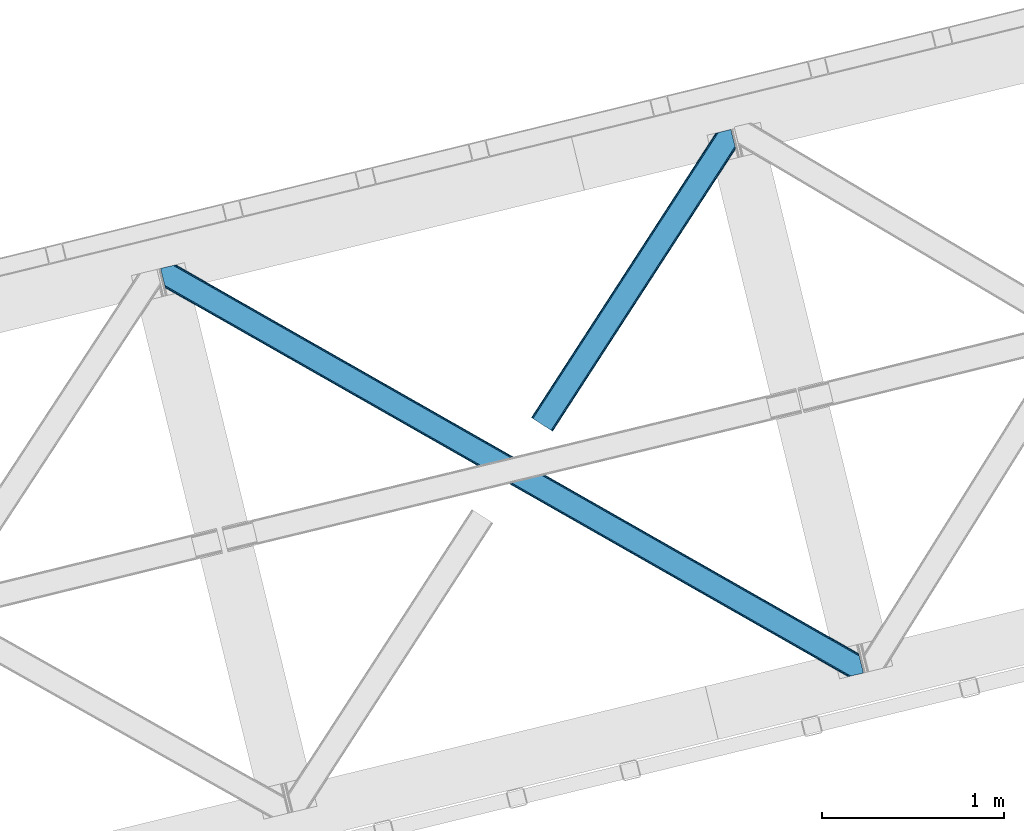
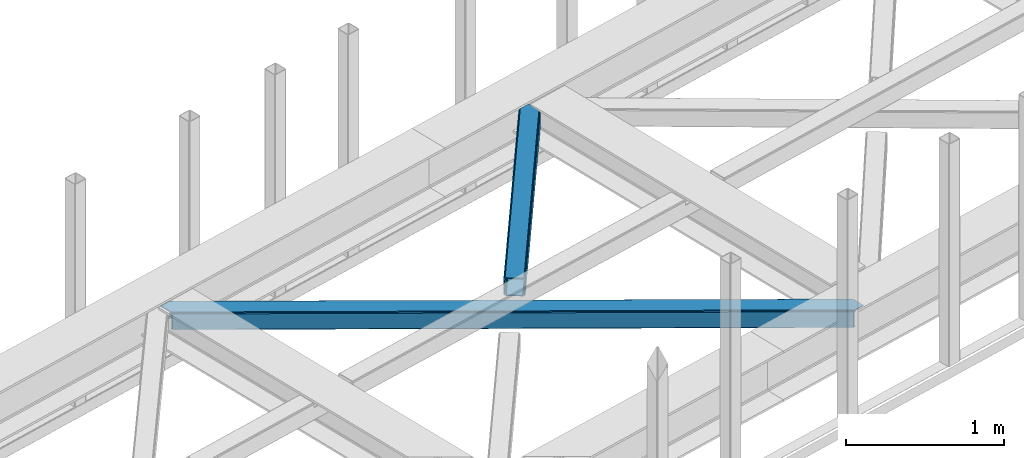
# One storey, part 37 of 66: 2 members.
"""IFC4 building model written with IfcOpenShell, lengths in millimetres."""

from ifc_helpers import new_model, entity, si_unit, converted_unit, derived_unit, direction, frame, origin, place, context, subcontext, project, spatial, triangles, type_object, element, save


model = new_model("IFC4")

# Units and contexts
model_context = context("Model", 3, precision=0.01, world=origin(), true_north=direction((6.12303176911189e-17, 1.0)))
plan_context = context("Plan", 3, precision=0.01, world=origin(), true_north=direction((6.12303176911189e-17, 1.0)))
body_context = subcontext(model_context, "Body", "Model", "MODEL_VIEW")
ifc_project = project(units=[si_unit("LENGTHUNIT", "METRE", prefix="MILLI"), si_unit("AREAUNIT", "SQUARE_METRE"), si_unit("VOLUMEUNIT", "CUBIC_METRE"), converted_unit("PLANEANGLEUNIT", "DEGREE", entity("IfcRatioMeasure", 0.0174532925199433), si_unit("PLANEANGLEUNIT", "RADIAN"), dimensions=[0, 0, 0, 0, 0, 0, 0]), si_unit("MASSUNIT", "GRAM", prefix="KILO"), derived_unit("MASSDENSITYUNIT", [(si_unit("MASSUNIT", "GRAM", prefix="KILO"), 1), (si_unit("LENGTHUNIT", "METRE"), -3)]), derived_unit("MOMENTOFINERTIAUNIT", [(si_unit("LENGTHUNIT", "METRE"), 4)]), si_unit("TIMEUNIT", "SECOND"), si_unit("FREQUENCYUNIT", "HERTZ"), si_unit("THERMODYNAMICTEMPERATUREUNIT", "DEGREE_CELSIUS"), derived_unit("THERMALTRANSMITTANCEUNIT", [(si_unit("MASSUNIT", "GRAM", prefix="KILO"), 1), (si_unit("THERMODYNAMICTEMPERATUREUNIT", "KELVIN"), -1), (si_unit("TIMEUNIT", "SECOND"), -3)]), derived_unit("VOLUMETRICFLOWRATEUNIT", [(si_unit("LENGTHUNIT", "METRE"), 3), (si_unit("TIMEUNIT", "SECOND"), -1)]), derived_unit("MASSFLOWRATEUNIT", [(si_unit("MASSUNIT", "GRAM", prefix="KILO"), 1), (si_unit("TIMEUNIT", "SECOND"), -1)]), derived_unit("ROTATIONALFREQUENCYUNIT", [(si_unit("TIMEUNIT", "SECOND"), -1)]), si_unit("ELECTRICCURRENTUNIT", "AMPERE"), si_unit("ELECTRICVOLTAGEUNIT", "VOLT"), si_unit("POWERUNIT", "WATT"), si_unit("FORCEUNIT", "NEWTON", prefix="KILO"), si_unit("ILLUMINANCEUNIT", "LUX"), si_unit("LUMINOUSFLUXUNIT", "LUMEN"), si_unit("LUMINOUSINTENSITYUNIT", "CANDELA"), derived_unit("USERDEFINED", [(si_unit("MASSUNIT", "GRAM", prefix="KILO"), -1), (si_unit("LENGTHUNIT", "METRE"), -2), (si_unit("TIMEUNIT", "SECOND"), 3), (si_unit("LUMINOUSFLUXUNIT", "LUMEN"), 1)]), derived_unit("LINEARVELOCITYUNIT", [(si_unit("LENGTHUNIT", "METRE"), 1), (si_unit("TIMEUNIT", "SECOND"), -1)]), si_unit("PRESSUREUNIT", "PASCAL"), derived_unit("USERDEFINED", [(si_unit("LENGTHUNIT", "METRE"), -2), (si_unit("MASSUNIT", "GRAM", prefix="KILO"), 1), (si_unit("TIMEUNIT", "SECOND"), -2)]), derived_unit("LINEARFORCEUNIT", [(si_unit("MASSUNIT", "GRAM", prefix="KILO"), 1), (si_unit("LENGTHUNIT", "METRE"), 1), (si_unit("TIMEUNIT", "SECOND"), -2), (si_unit("LENGTHUNIT", "METRE"), -1)]), derived_unit("PLANARFORCEUNIT", [(si_unit("MASSUNIT", "GRAM", prefix="KILO"), 1), (si_unit("LENGTHUNIT", "METRE"), 1), (si_unit("TIMEUNIT", "SECOND"), -2), (si_unit("LENGTHUNIT", "METRE"), -2)])], contexts=[model_context, plan_context])

# Site, building, storey
site_placement = place(None, origin())
site = spatial("IfcSite", under=ifc_project, at=site_placement, CompositionType="ELEMENT")
building_placement = place(site_placement, origin())
building = spatial("IfcBuilding", under=site, at=building_placement, CompositionType="ELEMENT")
storey_placement = place(building_placement, frame((0.0, 0.0, 19800.0)))
storey = spatial("IfcBuildingStorey", under=building, at=storey_placement, Name="06", CompositionType="ELEMENT", Elevation=19800.0)

# Members
member_type_1 = type_object("IfcMemberType", PredefinedType="BRACE")
member_1_placement = place(storey_placement, frame((-33302.32, 10419.12, 3823.06)))
element("IfcMember", 1, at=member_1_placement, inside=storey, type_object=member_type_1, ObjectType="Steel Horizontal Brace", PredefinedType="BRACE", context=body_context, shape_type="Tessellation", body=[
    triangles([(3770.60705566406, 0.0, 122.478570556643), (3772.49298706055, 0.459274291992188, 129.175836181643), (25.7193603515625, 2133.71162109375, 130.119964599609), (26.1542175292998, 2131.93149719238, 123.422698974609), (3777.86242675781, 1.767333984375, 134.852233886719), (24.4845520019517, 2138.77991638184, 135.79868774414), (3785.89449462891, 3.72651672363281, 138.645025634767), (22.6358276367173, 2146.36666259766, 139.593804931643), (3795.37298583984, 6.03684082031214, 139.975177001954), (20.454565429689, 2155.31379089356, 140.926281738281), (1898.4864440918, 1065.90586853027, 17.9500671386741), (2530.61995239258, 705.99644165039, 17.7919372558608), (3162.75346069336, 346.087014770508, 17.631481933593), (3770.60705566406, 0.0, 17.478002929689), (1266.35293579102, 1425.81529541016, 18.1105224609382), (26.1542175292998, 2131.93149719238, 18.4221313476555), (634.22175292969, 1785.72355957031, 18.2686523437515), (3834.64500732422, 104.50408630371, 139.977502441408), (3855.09957275391, 20.5952545166019, 139.963549804688), (59.7242614746137, 2253.78103637695, 140.93093261719), (0.0, 2239.22262268066, 140.940234375001), (3832.46607055664, 113.452377319336, 138.647351074218), (69.2027526855454, 2256.09136047363, 139.596130371094), (3830.61502075195, 121.037960815429, 134.854559326173), (77.2371459960923, 2258.04938049316, 135.801013183594), (3829.38021240235, 126.106256103516, 129.178161621094), (82.6065856933637, 2259.35860290527, 130.122290039064), (3828.94535522461, 127.886380004882, 122.480895996094), (84.490191650395, 2259.81787719727, 123.425024414064), (3220.89642333984, 474.082690429686, 17.6338073730476), (3828.94535522461, 127.886380004882, 17.4803283691399), (2588.76291503906, 833.99211730957, 17.7942626953118), (1956.62940673828, 1193.90154418945, 17.9547180175796), (1324.4958984375, 1553.81097106934, 18.1128479003928), (692.364715576172, 1913.72156066894, 18.273303222657), (84.490191650395, 2259.81787719727, 18.4267822265647), (3832.89627685547, 111.685043334961, 127.852661132813), (3832.89627685547, 111.685043334961, 12.1039123535156), (3833.99853515625, 107.15973815918, 9.46221313476781), (3829.58020019531, 125.287701416015, 9.46221313476781), (3831.65914306641, 116.753338623046, 122.176263427737), (3834.7450012207, 104.098297119141, 131.645452880861), (3836.92626342774, 95.1500061035149, 132.975604248048), (3855.09957275391, 20.5952545166019, 132.963977050782), (3831.22661132813, 118.533462524414, 115.478997802737), (3831.22661132813, 118.533462524414, 24.4799011230461), (3831.65914306641, 116.753338623046, 17.7826354980461), (3829.47090454102, 125.737673950194, 10.8528259277336), (1952.50407714844, 1188.19607849121, 24.9542907714858), (74.5838195800825, 2257.4029083252, 116.427777099609), (2588.61641235352, 826.021673583984, 24.793835449218), (3224.72874755859, 463.846105957031, 24.6333801269539), (1316.39406738281, 1550.37164611816, 25.11474609375), (74.5838195800825, 2257.4029083252, 25.4263549804709), (680.279406738282, 1912.54721374512, 25.2752014160178), (72.7002136230512, 2256.9436340332, 123.125042724609), (67.3307739257798, 2255.63557434082, 128.803765869143), (59.2940551757856, 2253.67639160156, 132.598883056642), (49.8202148437485, 2251.36723022461, 133.931359863283), (0.0, 2239.22262268066, 133.940661621094), (67.3307739257798, 2255.63557434082, 13.0550170898459), (81.762451171875, 2259.1539642334, 10.4412231445313), (72.7002136230512, 2256.9436340332, 18.7314147949219), (62.6054809570342, 2254.4833190918, 10.4412231445313), (82.2252136230454, 2259.26558532715, 11.7946289062493), (3805.27935791016, 8.45180969238208, 132.973278808593), (18.1733093261719, 2164.66787109375, 133.929034423829), (3795.80319213867, 6.14148559570276, 131.643127441406), (20.3545715332075, 2155.71958007812, 132.594232177737), (3787.76879882813, 4.18230285644495, 127.850335693362), (22.2032958984419, 2148.13399658203, 128.799114990234), (3782.39935913086, 2.87424316406214, 122.173937988282), (23.4404296875, 2143.06453857422, 123.122717285158), (3780.51342773438, 2.41496887206995, 115.476672363282), (23.8729614257827, 2141.28441467285, 116.425451660158), (3174.86434936523, 347.246246337891, 24.6287292480483), (3780.51342773438, 2.41496887206995, 24.4775756835952), (2538.75433959961, 709.420651245116, 24.7891845703125), (1902.64200439453, 1071.59505615234, 24.9496398925803), (1266.52966918945, 1433.76946105957, 25.1100952148445), (630.417333984376, 1795.9438659668, 25.2705505371086), (23.8729614257827, 2141.28441467285, 25.4240295410164), (23.4404296875, 2143.06453857422, 18.7267639160164), (25.526348876956, 2134.50575866699, 10.4412231445313), (22.2032958984419, 2148.13399658203, 13.0503662109368), (25.6333190918012, 2134.06973876953, 11.7923034667983), (21.1173156738296, 2152.58837585449, 10.4412231445313), (3787.76879882813, 4.18230285644495, 12.1015869140647), (3773.35805053711, 0.669726562498909, 9.46221313476781), (3782.39935913086, 2.87424316406214, 17.7803100585952), (3792.55455322266, 5.34967346191297, 9.46221313476781), (3772.88133544922, 0.554617309569949, 10.8481750488281), (3697.37896728516, 59.5847351074208, 9.46221313476781), (3701.80660400391, 41.4207275390618, 9.46221313476781), (153.281341552734, 2218.44482116699, 10.4412231445313), (157.68107299805, 2200.39708557129, 10.4412231445313), (154.658001708987, 2217.02514038086, 9.4412841796875), (159.494915771487, 2197.17402648926, 9.4412841796875), (159.143774414064, 2198.29140014648, 9.82498168945313), (154.325463867186, 2217.3681427002, 9.68312988281468), (158.657757568362, 2198.98903198242, 10.0296203613289), (153.969671630861, 2217.73439941406, 9.94125366210938), (158.167089843751, 2199.69829101562, 10.2365844726555), (153.613879394536, 2218.10181884766, 10.1993774414077), (193.244018554688, 2054.50599060059, 10.4412231445313), (197.636773681639, 2036.48848571777, 10.4412231445313), (193.823052978514, 2056.35122680664, 9.4412841796875), (198.650665283203, 2036.54313354492, 9.4412841796875), (193.769567871095, 2055.7105682373, 9.74824218749927), (198.466955566408, 2036.45825500488, 9.74126586914281), (193.713757324222, 2055.05479431152, 10.0598510742202), (198.266967773438, 2036.36523742676, 10.0668273925803), (193.657946777348, 2054.41297302246, 10.366809082032), (198.078607177733, 2036.27919616699, 10.366809082032), (3701.47406616211, 41.764892578125, 9.22036743164063), (3696.87899780273, 60.0172668457035, 9.38547363281396), (3701.11827392578, 42.1334747314449, 8.96224365234593), (3696.43716430664, 60.9648834228519, 9.07851562500218), (3700.76248168945, 42.5032196044922, 8.7041198730476), (3695.99067993164, 61.9218017578114, 8.76923217773583), (3700.42994384766, 42.8473846435536, 8.46227416992406), (3695.54884643555, 62.8694183349598, 8.46227416992406), (3163.41156005859, 347.245083618163, 10.934216308593), (634.879852294922, 1786.8827911377, 11.5737121582024), (636.754156494142, 1790.1791015625, 5.89498901367188), (197.780950927736, 2040.11268310547, 6.0066101074226), (3165.28586425781, 350.542556762695, 5.25781860351708), (3699.57883300781, 46.3401947021484, 5.1229431152351), (3697.72778320313, 53.9257781982415, 1.33015136718677), (3168.09499511719, 355.4759765625, 1.46502685546875), (3695.5465209961, 62.8740692138672, 0.0), (3171.40874633789, 361.296551513671, 0.132550048827397), (642.877038574221, 1800.9342590332, 0.76972045898583), (639.563287353518, 1795.11368408203, 2.10219726562718), (195.932226562501, 2047.69826660156, 2.21381835937427), (193.750964355473, 2056.64655761719, 0.8836669921875), (2539.27523803711, 721.205978393555, 0.290679931640625), (2535.96148681641, 715.385403442382, 1.62315673828198), (1907.14172973633, 1081.11540527344, 0.451135253908433), (1903.82797851563, 1075.29483032227, 1.78361206054615), (1275.00822143555, 1441.02483215332, 0.609265136718022), (1271.69447021485, 1435.20425720215, 1.94174194335938), (2533.15235595703, 710.451983642577, 5.41594848633031), (1901.01884765625, 1070.36141052246, 5.57640380859448), (1268.88766479492, 1430.27083740234, 5.73685913085865), (2531.27805175781, 707.154510498047, 11.0946716308608), (1899.14454345703, 1067.06393737793, 11.2528015136741), (1267.01103515625, 1426.97336425781, 11.4132568359382), (3661.34860839844, 203.171319580078, 0.0209289550803078), (3212.23416137695, 458.877804565429, 0.134875488281978), (2580.10297851563, 818.787231445313, 0.293005371095205), (1947.96947021484, 1178.69665832519, 0.453460693359375), (683.702453613281, 1898.51551208496, 0.772045898436772), (1315.83596191406, 1538.60608520508, 0.613916015627183), (159.553051757815, 2196.9438079834, 0.904595947267808), (3177.39675292969, 351.70062561035, 12.2550659179688), (3180.20588378907, 356.635208129883, 8.46227416992406), (3695.44420166016, 63.299624633788, 8.39483642578125), (3693.26759033203, 72.2269866943352, 7.00189819336083), (639.072619628907, 1811.15340270996, 7.77161865234302), (191.472033691411, 2065.99947509766, 7.88323974609375), (193.643994140628, 2057.08722839356, 9.32268676758031), (632.952062988283, 1800.39940795898, 12.8968872070327), (635.758868408204, 1805.33399047852, 9.10409545898438), (631.075433349612, 1797.10309753418, 18.5756103515632), (3183.51963500977, 362.455783081054, 7.12979736328271), (3175.52244873047, 348.404315185546, 17.9337890624993), (2539.41011352539, 710.578720092773, 18.0942443847671), (1903.30010375977, 1072.753125, 18.2546997070313), (1267.18776855469, 1434.92752990723, 18.4151550292991), (2541.28674316406, 713.876193237304, 12.4155212402366), (1905.17440795898, 1076.05059814453, 12.5759765625007), (1269.06439819336, 1438.22500305176, 12.7364318847649), (2544.09587402344, 718.810775756836, 8.62272949218823), (1907.98353881836, 1080.98518066406, 8.7831848144524), (1271.87352905274, 1443.15958557129, 8.94364013672021), (2547.40962524414, 724.630187988281, 7.29025268554688), (1911.29729003906, 1086.80459289551, 7.45070800781468), (1275.18495483399, 1448.97899780273, 7.61116333007885), (155.520739746098, 2213.47884521484, 6.03218994140843), (157.37178955078, 2205.89209899902, 2.23707275390552), (161.831982421878, 2187.59089050293, 7.90416870117406), (159.657696533206, 2196.50778808594, 9.33431396484593), (3216.0664855957, 448.640057373046, 7.13212280273365), (2579.95647583008, 810.815624999999, 7.29257812500146), (1943.84181518555, 1172.99119262695, 7.45303344726563), (3663.6275390625, 193.818402099609, 7.02050170898656), (671.617144775391, 1897.34000244141, 7.7739440917976), (1307.72947998047, 1535.16559753418, 7.61348876953343), (3220.23832397461, 472.926947021484, 10.9365417480476), (3218.35704345703, 469.630636596679, 5.26014404296802), (3656.48843994141, 223.423571777343, 8.84597167968968), (3656.47216186524, 223.174749755859, 8.46227416992406), (3657.48372802735, 223.244512939453, 9.46221313476781), (3656.81400146485, 223.365435791015, 9.04595947265625), (3657.31862182617, 219.705194091797, 5.14852294922093), (691.704290771486, 1912.56465454101, 11.576037597657), (689.82533569336, 1909.26834411621, 5.89731445312646), (687.016204833984, 1904.33492431641, 2.10452270507813), (3659.16734619141, 212.119610595702, 1.3557312011726), (3215.54791259766, 464.697216796874, 1.46735229492333), (2588.10481567383, 832.836373901368, 11.0969970703118), (1955.97130737305, 1192.74580078125, 11.2574523925796), (1323.83779907227, 1552.65522766113, 11.4155822753928), (2586.22353515625, 829.540063476563, 5.42059936523583), (1954.09235229492, 1189.44949035644, 5.57872924804906), (1321.95884399414, 1549.35891723633, 5.73918457031323), (2583.41440429688, 824.606643676758, 1.62548217773656), (1951.28322143555, 1184.51607055664, 1.78593750000073), (1319.14971313477, 1544.42549743652, 1.94406738281396), (674.930895996094, 1903.16057739258, 9.10642089843896), (677.742352294925, 1908.09399719238, 12.8992126464836), (3661.36256103516, 203.10969543457, 8.46227416992406), (3661.92066650391, 205.049111938477, 9.46221313476781), (3222.19169311524, 459.394052124024, 12.2573913574233), (3219.38023681641, 454.459469604491, 8.464599609375), (3661.30209960938, 203.975921630859, 8.81574096679833), (3661.24396362305, 204.843310546874, 9.1692077636726), (679.618981933596, 1911.38914489746, 18.5779357910178), (3224.06832275391, 462.689199829101, 17.9361145019539), (2583.26790161133, 816.635037231445, 8.62505493164281), (1947.15556640625, 1178.8106048584, 8.78551025390698), (1311.04323120117, 1540.98500976563, 8.94596557617115), (2586.0770324707, 821.56845703125, 12.4178466796875), (1949.96469726563, 1183.74286193848, 12.5783020019553), (1313.8546875, 1545.91842956543, 12.7387573242195), (2587.95598754883, 824.864767456054, 18.096569824218), (1951.84365234375, 1187.04033508301, 18.2570251464858), (1315.73131713867, 1549.21473999023, 18.41748046875)], [[1, 2, 3], [3, 4, 1], [2, 5, 6], [6, 3, 2], [5, 7, 8], [8, 6, 5], [7, 9, 10], [10, 8, 7], [11, 1, 4], [1, 12, 13], [11, 12, 1], [13, 14, 1], [15, 11, 4], [4, 16, 17], [17, 15, 4], [9, 18, 10], [9, 19, 18], [20, 10, 18], [21, 10, 20], [18, 22, 23], [23, 20, 18], [22, 24, 25], [25, 23, 22], [24, 26, 27], [27, 25, 24], [26, 28, 29], [29, 27, 26], [30, 28, 31], [28, 30, 32], [28, 33, 29], [33, 28, 32], [29, 33, 34], [34, 35, 29], [36, 29, 35], [37, 24, 22], [38, 39, 40], [24, 37, 41], [42, 37, 22], [42, 18, 43], [19, 43, 18], [43, 19, 44], [42, 22, 18], [31, 45, 46], [40, 47, 38], [47, 31, 46], [48, 47, 40], [48, 31, 47], [28, 45, 31], [41, 26, 24], [28, 26, 41], [45, 28, 41], [49, 45, 50], [45, 51, 52], [49, 51, 45], [52, 46, 45], [53, 49, 50], [50, 54, 55], [55, 53, 50], [45, 41, 50], [56, 50, 41], [41, 37, 56], [57, 56, 37], [37, 42, 57], [58, 57, 42], [42, 43, 58], [59, 58, 43], [56, 29, 27], [58, 23, 20], [21, 59, 20], [59, 21, 60], [59, 58, 20], [57, 23, 58], [57, 56, 25], [25, 23, 57], [27, 25, 56], [54, 36, 29], [61, 62, 63], [56, 50, 29], [61, 64, 62], [54, 63, 36], [50, 54, 29], [65, 36, 63], [63, 62, 65], [43, 66, 67], [66, 43, 44], [67, 59, 43], [60, 59, 67], [66, 68, 67], [69, 67, 68], [68, 70, 69], [71, 69, 70], [70, 72, 71], [73, 71, 72], [72, 74, 73], [75, 73, 74], [76, 74, 77], [74, 76, 78], [74, 79, 75], [79, 74, 78], [75, 79, 80], [80, 81, 75], [82, 75, 81], [83, 84, 85], [82, 4, 16], [16, 86, 83], [86, 84, 83], [83, 82, 16], [75, 4, 82], [73, 71, 6], [3, 73, 6], [3, 4, 73], [75, 73, 4], [71, 8, 6], [69, 8, 71], [87, 85, 84], [69, 67, 10], [69, 10, 8], [67, 21, 10], [67, 60, 21], [72, 1, 2], [68, 7, 9], [66, 19, 44], [9, 66, 68], [66, 9, 19], [70, 7, 68], [70, 72, 5], [5, 7, 70], [2, 5, 72], [14, 1, 74], [88, 89, 90], [72, 74, 1], [88, 91, 89], [77, 90, 14], [77, 14, 74], [92, 14, 90], [90, 89, 92], [91, 89, 93], [94, 93, 89], [95, 96, 62], [64, 62, 96], [97, 98, 99], [100, 99, 101], [102, 101, 103], [104, 103, 96], [96, 95, 104], [103, 104, 102], [101, 102, 100], [99, 100, 97], [105, 106, 84], [84, 87, 105], [107, 108, 109], [110, 109, 108], [109, 110, 111], [112, 111, 110], [111, 112, 113], [114, 113, 112], [113, 114, 106], [106, 105, 113], [115, 116, 93], [117, 118, 116], [119, 120, 118], [121, 122, 120], [120, 119, 121], [118, 117, 119], [116, 115, 117], [93, 94, 115], [123, 92, 14], [124, 17, 16], [110, 125, 112], [110, 108, 125], [114, 112, 125], [108, 126, 125], [124, 86, 106], [106, 125, 124], [106, 114, 125], [86, 84, 106], [92, 123, 94], [123, 127, 128], [128, 121, 123], [115, 123, 117], [115, 94, 123], [123, 119, 117], [123, 121, 119], [94, 89, 92], [129, 128, 127], [127, 130, 129], [131, 129, 130], [130, 132, 131], [133, 134, 135], [135, 136, 133], [134, 125, 126], [126, 135, 134], [16, 86, 124], [14, 13, 123], [132, 130, 137], [138, 137, 130], [137, 138, 139], [140, 139, 138], [139, 140, 141], [142, 141, 140], [141, 142, 133], [134, 133, 142], [130, 127, 143], [143, 138, 130], [138, 143, 144], [144, 140, 138], [140, 144, 145], [145, 142, 140], [142, 145, 125], [125, 134, 142], [127, 123, 143], [146, 143, 123], [143, 146, 144], [147, 144, 146], [144, 147, 145], [148, 145, 147], [145, 148, 125], [124, 125, 148], [123, 13, 12], [12, 146, 123], [146, 12, 11], [11, 147, 146], [147, 11, 15], [15, 148, 147], [148, 15, 17], [17, 124, 148], [149, 131, 132], [150, 132, 137], [132, 150, 149], [151, 139, 152], [137, 151, 150], [151, 137, 139], [133, 153, 154], [152, 141, 154], [141, 152, 139], [141, 133, 154], [136, 153, 133], [155, 153, 136], [156, 116, 118], [118, 157, 156], [118, 120, 157], [122, 157, 120], [122, 158, 157], [88, 91, 93], [93, 156, 88], [93, 116, 156], [157, 158, 159], [160, 161, 162], [163, 113, 105], [105, 85, 163], [105, 87, 85], [164, 162, 107], [107, 163, 164], [163, 109, 111], [109, 163, 107], [111, 113, 163], [81, 165, 82], [83, 82, 165], [165, 163, 83], [85, 83, 163], [162, 164, 160], [159, 166, 157], [90, 88, 156], [156, 167, 90], [77, 90, 167], [167, 76, 77], [76, 167, 168], [168, 78, 76], [78, 168, 79], [169, 79, 168], [79, 169, 80], [170, 80, 169], [80, 170, 81], [165, 81, 170], [167, 156, 168], [171, 168, 156], [168, 171, 172], [172, 169, 168], [169, 172, 173], [173, 170, 169], [170, 173, 163], [163, 165, 170], [156, 157, 174], [174, 171, 156], [171, 174, 172], [175, 172, 174], [172, 175, 173], [176, 173, 175], [173, 176, 163], [164, 163, 176], [157, 166, 174], [177, 174, 166], [174, 177, 178], [178, 175, 174], [175, 178, 179], [179, 176, 175], [176, 179, 160], [160, 164, 176], [98, 180, 181], [155, 98, 181], [182, 183, 155], [182, 155, 161], [180, 98, 97], [155, 183, 98], [161, 136, 162], [136, 135, 107], [136, 161, 155], [126, 107, 135], [136, 107, 162], [126, 108, 107], [177, 166, 184], [184, 185, 177], [185, 178, 177], [178, 185, 186], [166, 187, 184], [166, 159, 187], [188, 160, 189], [160, 188, 161], [182, 161, 188], [179, 189, 160], [186, 179, 178], [189, 179, 186], [190, 30, 31], [191, 192, 193], [190, 48, 194], [194, 191, 190], [194, 195, 191], [48, 40, 194], [193, 196, 191], [65, 197, 95], [197, 198, 180], [180, 97, 197], [197, 97, 102], [102, 95, 197], [197, 65, 36], [36, 35, 197], [95, 62, 65], [198, 199, 181], [181, 180, 198], [199, 153, 155], [155, 181, 199], [200, 149, 150], [150, 201, 200], [196, 200, 201], [201, 191, 196], [31, 48, 190], [30, 190, 32], [202, 32, 190], [32, 202, 33], [203, 33, 202], [33, 203, 34], [204, 34, 203], [34, 204, 197], [197, 35, 34], [190, 191, 205], [205, 202, 190], [202, 205, 206], [206, 203, 202], [203, 206, 207], [207, 204, 203], [204, 207, 198], [198, 197, 204], [191, 201, 205], [208, 205, 201], [205, 208, 206], [209, 206, 208], [206, 209, 207], [210, 207, 209], [207, 210, 198], [199, 198, 210], [201, 150, 208], [151, 208, 150], [208, 151, 152], [152, 209, 208], [209, 152, 154], [154, 210, 209], [210, 154, 153], [153, 199, 210], [211, 99, 183], [212, 103, 101], [212, 96, 103], [101, 211, 212], [101, 99, 211], [61, 64, 96], [96, 212, 61], [211, 183, 182], [184, 187, 213], [214, 38, 215], [214, 39, 38], [213, 215, 216], [217, 218, 215], [215, 213, 217], [213, 216, 184], [182, 188, 211], [212, 219, 63], [63, 61, 212], [219, 55, 54], [54, 63, 219], [47, 46, 220], [52, 220, 46], [38, 47, 215], [220, 215, 47], [184, 216, 185], [221, 185, 216], [185, 221, 186], [222, 186, 221], [186, 222, 189], [223, 189, 222], [189, 223, 188], [211, 188, 223], [216, 215, 224], [224, 221, 216], [221, 224, 225], [225, 222, 221], [222, 225, 226], [226, 223, 222], [223, 226, 212], [212, 211, 223], [215, 220, 224], [227, 224, 220], [224, 227, 225], [228, 225, 227], [225, 228, 226], [229, 226, 228], [226, 229, 212], [219, 212, 229], [220, 52, 51], [51, 227, 220], [227, 51, 49], [49, 228, 227], [228, 49, 53], [53, 229, 228], [229, 53, 55], [55, 219, 229], [149, 187, 159], [213, 196, 193], [149, 213, 187], [213, 200, 196], [213, 149, 200], [131, 149, 159], [158, 131, 159], [128, 158, 121], [158, 129, 131], [158, 128, 129], [214, 217, 193], [217, 213, 193], [40, 39, 214], [214, 194, 40]]),
])
member_type_2 = type_object("IfcMemberType", PredefinedType="BRACE")
member_2_placement = place(storey_placement, frame((-31269.04, 11764.69, 3823.58)))
element("IfcMember", 2, at=member_2_placement, inside=storey, type_object=member_type_2, ObjectType="Steel Horizontal Brace", PredefinedType="BRACE", context=body_context, shape_type="Tessellation", body=[
    triangles([(972.968518066409, 1545.29288635254, 0.386022949220205), (1007.16875610352, 1404.99563598633, 0.365093994139897), (14.7014282226592, 66.6447692871097, 0.0), (102.814654541016, 9.54011535644531, 0.0), (1.13248901367479, 75.4349304199222, 10.8039916992202), (0.011627197265625, 76.1581420898438, 17.4989318847656), (1010.67784423828, 1635.6559753418, 17.9082092285171), (968.503674316409, 1566.80901489258, 9.6808044433601), (4.31601562500146, 73.3734283447266, 5.12526855468604), (968.640875244142, 1567.26712646485, 9.92265014648365), (968.357171630862, 1566.32067260742, 9.42268066406177), (968.210668945314, 1565.83116760254, 9.16455688476708), (968.073468017581, 1565.37421875, 8.9227111816399), (968.938531494143, 1561.82676086426, 5.51361694336083), (1012.94282226563, 1636.20826721191, 11.2760559082017), (1013.40325927734, 1636.32105102539, 9.92265014648365), (970.787255859377, 1554.24117736817, 1.71849975585792), (9.07851562500218, 70.2864074707031, 1.33247680664135), (1010.67784423828, 1635.6559753418, 122.906451416016), (0.0, 76.1395385742198, 122.499499511719), (1012.56145019531, 1636.11524963379, 129.603717041016), (1.11853637695458, 75.4140014648438, 129.196765136719), (1017.92856445313, 1637.42330932617, 135.282440185547), (4.29973754883031, 73.3490112304698, 134.873162841795), (1025.96528320313, 1639.38249206543, 139.077557373046), (9.06456298828198, 70.2608276367191, 138.668280029298), (1035.44377441406, 1641.69281616211, 140.412359619142), (14.6828247070334, 66.6191894531257, 140.000756835936), (973.040606689454, 1549.21939086914, 9.92265014648365), (972.796435546876, 1548.6089630127, 9.84823608398438), (972.833642578127, 1547.58344421387, 9.5412780761726), (972.87317504883, 1546.54862365723, 9.22966918945167), (972.912707519532, 1545.5231048584, 8.9227111816399), (1032.56255493164, 1640.99053344727, 9.92265014648365), (14.9525756835938, 66.4773376464855, 8.3320495605476), (20.5754882812507, 62.8368621826176, 6.99957275390625), (975.249774169923, 1535.93996887207, 7.38559570312646), (10.1877502441421, 69.5655212402344, 12.1248413085923), (1027.83726196289, 1639.83827819824, 12.5364440917983), (973.075488281251, 1544.85570373535, 8.81574096679833), (1022.46782226563, 1638.53021850586, 18.2128417968743), (1020.58421630859, 1638.07094421387, 24.9077819824233), (7.00422363281541, 71.6270233154301, 17.8035644531265), (5.88568725586083, 72.3502349853516, 24.5008300781265), (1004.8875, 1414.3485534668, 7.36466674804615), (96.9382690429702, 13.3456970214847, 6.99957275390625), (1007.06178588867, 1405.4363067627, 8.80411376953271), (1007.24084472656, 1404.70030517578, 8.9227111816399), (1012.06845703125, 1384.89221191406, 8.9227111816399), (1011.19874267578, 1388.46176147461, 5.488037109375), (1009.35001831055, 1396.0473449707, 1.69524536132667), (1020.58421630859, 1638.07094421387, 115.909204101561), (5.87638549804979, 72.3339569091804, 115.499926757813), (1035.87398071289, 1641.7974609375, 132.080310058594), (1045.34782104492, 1644.10778503418, 133.412786865236), (20.5592102050796, 62.8124450683608, 132.998858642579), (14.9386230468772, 66.4552459716797, 131.668707275392), (1027.83726196289, 1639.83827819824, 128.285192871095), (10.1737976074219, 69.5434295654304, 127.873590087889), (1022.46782226563, 1638.53021850586, 122.606469726561), (6.99259643554979, 71.6084197998061, 122.197192382813), (1095.16803588867, 1656.2512298584, 140.421661376953), (1095.16803588867, 1656.2512298584, 133.422088623047), (1115.62260131836, 1572.34239807129, 140.407708740233), (102.798376464845, 9.5145355224613, 140.000756835936), (1113.34134521485, 1581.69647827149, 133.410461425781), (96.92431640625, 13.3224426269535, 132.998858642579), (1117.80153808594, 1563.39526977539, 139.075231933595), (108.418963623048, 5.87289733886792, 138.668280029298), (1119.65258789063, 1555.80852355957, 135.280114746092), (113.181463623048, 2.78587646484448, 134.873162841795), (1120.88739624024, 1550.74022827148, 129.601391601562), (116.36731567383, 0.72321166992333, 129.196765136719), (1121.32225341797, 1548.96010437012, 122.904125976562), (117.485852050784, 0.0, 122.499499511719), (1121.32225341797, 1548.96010437012, 17.9035583496079), (117.499804687501, 0.0197662353530177, 17.4989318847656), (107.309729003908, 6.59378356933667, 127.873590087889), (110.495581054689, 4.53228149414099, 122.197192382813), (111.611791992189, 3.80790710449219, 115.499926757813), (102.544903564456, 9.6808044433601, 131.668707275392), (116.38126831055, 0.74530334472729, 10.8039916992202), (107.323681640628, 6.61471252441515, 12.1248413085923), (113.197741699219, 2.80913085937573, 5.12526855468604), (111.623419189455, 3.82534790039063, 24.5008300781265), (110.507208251955, 4.55088500976672, 17.8035644531265), (108.432916259768, 5.89731445312646, 1.33247680664135), (102.558856201173, 9.70289611816406, 8.3320495605476), (1118.60846557617, 1560.09314575195, 122.60414428711), (1119.04099731446, 1558.31302185059, 115.90687866211), (1117.37133178711, 1565.16260375977, 128.280541992186), (1115.52260742188, 1572.74818725586, 132.075659179689), (1119.04099731446, 1558.31302185059, 24.9054565429688), (1118.60846557617, 1560.09314575195, 18.2081909179688), (1120.69438476563, 1551.53436584473, 9.92265014648365), (1117.37133178711, 1565.16260375977, 12.5317932128892), (1120.79902954102, 1551.09834594727, 11.2737304687507), (1116.2853515625, 1569.61698303223, 9.92265014648365), (1012.19868164063, 1384.68524780274, 9.30640869140552), (1012.7358581543, 1385.10731506348, 9.72266235351708), (1012.99630737305, 1385.31079101563, 9.92265014648365), (1008.6035522461, 1403.32829589844, 9.92265014648365), (1007.57570800781, 1403.93872375488, 9.27617797851417)], [[1, 2, 3], [4, 3, 2], [5, 6, 7], [8, 9, 10], [9, 8, 11], [12, 9, 11], [9, 12, 13], [13, 14, 9], [5, 15, 10], [10, 9, 5], [15, 16, 10], [17, 1, 18], [3, 18, 1], [14, 17, 9], [18, 9, 17], [7, 15, 5], [19, 7, 20], [6, 20, 7], [21, 19, 22], [20, 22, 19], [23, 21, 24], [22, 24, 21], [25, 23, 26], [24, 26, 23], [27, 25, 28], [26, 28, 25], [8, 10, 29], [11, 8, 30], [12, 11, 31], [13, 12, 32], [32, 33, 13], [31, 32, 12], [30, 31, 11], [29, 30, 8], [16, 34, 29], [29, 10, 16], [35, 36, 37], [38, 30, 29], [29, 39, 38], [29, 34, 39], [38, 35, 40], [40, 33, 38], [31, 38, 32], [31, 30, 38], [38, 33, 32], [37, 40, 35], [41, 42, 43], [44, 43, 42], [39, 41, 38], [43, 38, 41], [45, 37, 36], [36, 46, 45], [1, 37, 45], [13, 33, 14], [33, 40, 1], [37, 1, 40], [33, 17, 14], [33, 1, 17], [2, 1, 45], [2, 45, 47], [48, 2, 47], [49, 50, 48], [48, 51, 2], [48, 50, 51], [42, 52, 53], [53, 44, 42], [54, 55, 56], [56, 57, 54], [58, 54, 57], [57, 59, 58], [60, 58, 59], [59, 61, 60], [52, 60, 61], [61, 53, 52], [60, 19, 21], [54, 25, 27], [62, 55, 27], [55, 62, 63], [55, 54, 27], [58, 25, 54], [58, 60, 23], [23, 25, 58], [21, 23, 60], [42, 7, 19], [39, 16, 41], [60, 52, 19], [39, 34, 16], [42, 41, 7], [52, 42, 19], [15, 7, 41], [41, 16, 15], [64, 27, 28], [27, 64, 62], [28, 65, 64], [55, 66, 56], [55, 63, 66], [67, 56, 66], [68, 64, 65], [65, 69, 68], [70, 68, 69], [69, 71, 70], [72, 70, 71], [71, 73, 72], [74, 72, 73], [73, 75, 74], [76, 74, 75], [75, 77, 76], [73, 78, 79], [80, 77, 75], [73, 79, 75], [73, 71, 78], [79, 80, 75], [78, 71, 69], [67, 65, 28], [65, 81, 69], [81, 65, 67], [81, 78, 69], [82, 83, 84], [85, 77, 80], [77, 86, 82], [86, 77, 85], [82, 86, 83], [4, 46, 3], [87, 84, 83], [83, 88, 87], [88, 46, 4], [4, 87, 88], [59, 26, 24], [28, 56, 67], [28, 57, 56], [57, 28, 26], [59, 57, 26], [53, 20, 6], [22, 61, 59], [24, 22, 59], [61, 22, 20], [53, 61, 20], [18, 38, 9], [3, 46, 36], [36, 35, 3], [35, 38, 18], [18, 3, 35], [5, 9, 38], [6, 44, 53], [43, 6, 5], [6, 43, 44], [43, 5, 38], [89, 90, 79], [80, 79, 90], [91, 89, 78], [79, 78, 89], [92, 91, 81], [78, 81, 91], [66, 92, 67], [81, 67, 92], [90, 93, 80], [85, 80, 93], [94, 95, 96], [93, 74, 76], [76, 97, 94], [97, 95, 94], [94, 93, 76], [90, 74, 93], [89, 91, 70], [72, 89, 70], [72, 74, 89], [90, 89, 74], [91, 68, 70], [92, 68, 91], [98, 96, 95], [92, 66, 64], [92, 64, 68], [66, 62, 64], [66, 63, 62], [82, 97, 76], [82, 99, 100], [101, 97, 82], [101, 95, 97], [84, 50, 99], [99, 82, 84], [51, 50, 87], [84, 87, 50], [2, 51, 4], [87, 4, 51], [76, 77, 82], [102, 103, 88], [48, 88, 103], [83, 96, 102], [102, 88, 83], [96, 98, 102], [46, 88, 48], [48, 45, 46], [94, 96, 83], [83, 86, 94], [93, 94, 86], [86, 85, 93], [99, 48, 103], [99, 103, 102], [98, 95, 102], [101, 102, 95]]),
])

save(model, "model.ifc")
